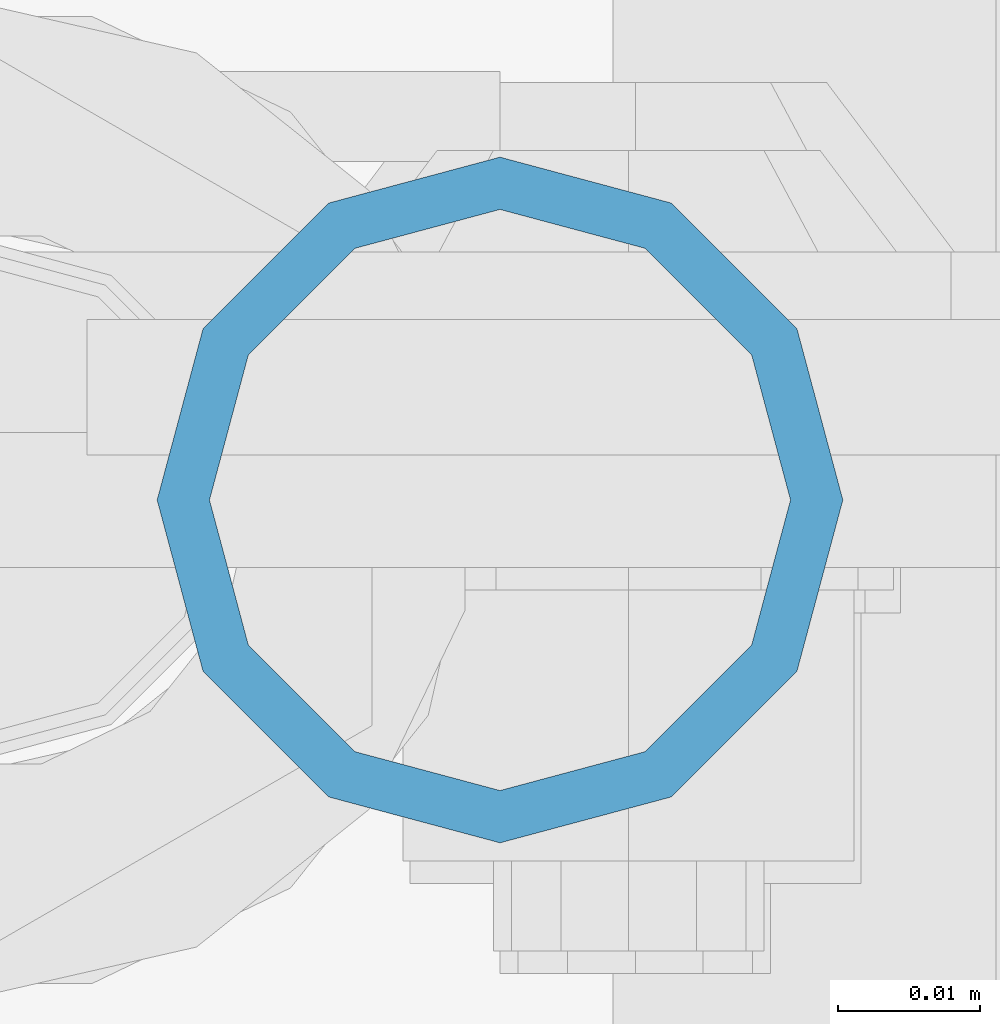
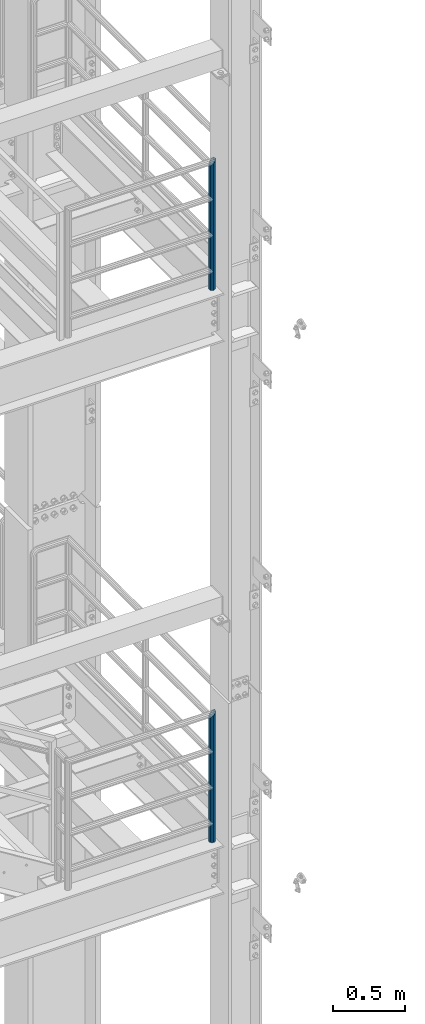
# One storey, part 589 of 1876: 2 columns, 2 elements without a shape of their own.
"""IFC2X3 building model written with IfcOpenShell, lengths in millimetres."""

from ifc_helpers import new_model, si_unit, frame, origin_with_axes, place, context, subcontext, project, spatial, faceted_brep, material, type_object, element, aggregate, save


model = new_model("IFC2X3")

# Units and contexts
model_context = context("Model", 3, precision=1e-05, world=origin_with_axes())
body_context = subcontext(model_context, "Body", "Model", "MODEL_VIEW")
ifc_project = project(units=[si_unit("LENGTHUNIT", "METRE", prefix="MILLI"), si_unit("AREAUNIT", "SQUARE_METRE"), si_unit("VOLUMEUNIT", "CUBIC_METRE"), si_unit("MASSUNIT", "GRAM", prefix="KILO"), si_unit("TIMEUNIT", "SECOND"), si_unit("PLANEANGLEUNIT", "RADIAN"), si_unit("SOLIDANGLEUNIT", "STERADIAN"), si_unit("THERMODYNAMICTEMPERATUREUNIT", "DEGREE_CELSIUS"), si_unit("LUMINOUSINTENSITYUNIT", "LUMEN")], contexts=[model_context])

# Site, building, storey
site_placement = place(None, origin_with_axes())
site = spatial("IfcSite", under=ifc_project, at=site_placement, CompositionType="ELEMENT")
building_placement = place(site_placement, origin_with_axes())
building = spatial("IfcBuilding", under=site, at=building_placement, Name="Undefined", CompositionType="ELEMENT")
storey_placement = place(building_placement, origin_with_axes())
storey = spatial("IfcBuildingStorey", under=building, at=storey_placement, Name="Undefined", CompositionType="ELEMENT", Elevation=0.0)

# Assembly, column
assembly_1_placement = place(storey_placement, origin_with_axes())
assembly_1 = element("IfcElementAssembly", 1, at=assembly_1_placement, inside=storey, Name="RAIL", AssemblyPlace="NOTDEFINED", PredefinedType="RIGID_FRAME")
ifc_material = material()
column_type = type_object("IfcColumnType", Name="PIPE1-1/2SCH40", PredefinedType="NOTDEFINED")
column_1_placement = place(assembly_1_placement, frame((7427.9125, -7112.0, 17983.2), z_axis=(0.0, 1.0, 0.0), x_axis=(0.0, 0.0, 1.0)))
column_1 = element("IfcColumn", 2, at=column_1_placement, type_object=column_type, material=ifc_material, Name="POST", ObjectType="PIPE1-1/2SCH40", context=body_context, shape_type="Brep", body=[
    faceted_brep([(0.0, -20.4469999999999, 0.0), (0.0, -17.7076214311803, 10.2235000000001), (1058.61737856882, -17.7076214311803, 10.2235000000001), (1055.878, -20.4469999999999, 0.0), (0.0, -10.2235000000001, 17.7076214311801), (1066.1015, -10.2235000000001, 17.7076214311801), (-1.45519152283669e-11, 0.0, 20.4470000000001), (1076.325, 0.0, 20.4470000000001), (0.0, 10.2235000000001, 17.7076214311801), (1086.5485, 10.2235000000001, 17.7076214311801), (0.0, 17.7076214311803, 10.2235000000001), (1094.03262143118, 17.7076214311803, 10.2235000000001), (0.0, 20.4469999999999, 0.0), (1096.772, 20.4469999999999, 0.0), (0.0, 17.7076214311803, -10.2235000000001), (1094.03262143118, 17.7076214311803, -10.2235000000001), (0.0, 10.2235000000001, -17.7076214311801), (1086.5485, 10.2235000000001, -17.7076214311801), (-1.45519152283669e-11, 0.0, -20.4470000000001), (1076.325, 0.0, -20.4470000000001), (0.0, -10.2235000000001, -17.7076214311801), (1066.1015, -10.2235000000001, -17.7076214311801), (0.0, -17.7076214311803, -10.2235000000001), (1058.61737856882, -17.7076214311803, -10.2235000000001), (0.0, -24.1299999999992, 0.0), (0.0, -20.8971929933184, -12.0649999999996), (1055.42780700668, -20.8971929933184, -12.0649999999996), (1052.195, -24.1300000000001, 0.0), (0.0, -12.0650000000001, -20.8971929933186), (1064.26, -12.0650000000001, -20.8971929933186), (-1.45519152283669e-11, 0.0, -24.130000000001), (1076.325, 0.0, -24.1300000000001), (0.0, 12.0650000000001, -20.8971929933186), (1088.39, 12.0650000000001, -20.8971929933186), (0.0, 20.8971929933184, -12.0649999999996), (1097.22219299332, 20.8971929933184, -12.0649999999996), (0.0, 24.1299999999992, 0.0), (1100.455, 24.1300000000001, 0.0), (0.0, 20.8971929933184, 12.0649999999996), (1097.22219299332, 20.8971929933184, 12.0649999999996), (0.0, 12.0650000000001, 20.8971929933186), (1088.39, 12.0650000000001, 20.8971929933186), (-1.45519152283669e-11, 0.0, 24.130000000001), (1076.325, 0.0, 24.1300000000001), (0.0, -12.0650000000001, 20.8971929933186), (1064.26, -12.0650000000001, 20.8971929933186), (0.0, -20.8971929933184, 12.0649999999996), (1055.42780700668, -20.8971929933184, 12.0649999999996)], [[[0, 1, 2, 3]], [[1, 4, 5, 2]], [[4, 6, 7, 5]], [[6, 8, 9, 7]], [[8, 10, 11, 9]], [[10, 12, 13, 11]], [[12, 14, 15, 13]], [[14, 16, 17, 15]], [[16, 18, 19, 17]], [[18, 20, 21, 19]], [[20, 22, 23, 21]], [[22, 0, 3, 23]], [[24, 25, 26, 27]], [[25, 28, 29, 26]], [[28, 30, 31, 29]], [[30, 32, 33, 31]], [[32, 34, 35, 33]], [[34, 36, 37, 35]], [[36, 38, 39, 37]], [[38, 40, 41, 39]], [[40, 42, 43, 41]], [[42, 44, 45, 43]], [[44, 46, 47, 45]], [[46, 24, 27, 47]], [[29, 31, 33, 35, 37, 39, 41, 43, 45, 47, 27, 26], [5, 7, 9, 11, 13, 15, 17, 19, 21, 23, 3, 2]], [[46, 44, 42, 40, 38, 36, 34, 32, 30, 28, 25, 24], [22, 20, 18, 16, 14, 12, 10, 8, 6, 4, 1, 0]]]),
])
aggregate(assembly_1, [column_1])

assembly_2_placement = place(storey_placement, origin_with_axes())
assembly_2 = element("IfcElementAssembly", 3, at=assembly_2_placement, inside=storey, Name="RAIL", AssemblyPlace="NOTDEFINED", PredefinedType="RIGID_FRAME")
column_2_placement = place(assembly_2_placement, frame((7427.9125, -7112.0, 13309.6), z_axis=(0.0, 1.0, 0.0), x_axis=(0.0, 0.0, 1.0)))
column_2 = element("IfcColumn", 4, at=column_2_placement, type_object=column_type, material=ifc_material, Name="POST", ObjectType="PIPE1-1/2SCH40", context=body_context, shape_type="Brep", body=[
    faceted_brep([(0.0, -20.4469999999999, 0.0), (0.0, -17.7076214311803, 10.2235000000001), (1058.61737856882, -17.7076214311803, 10.2235000000001), (1055.878, -20.4469999999999, 0.0), (0.0, -10.2235000000001, 17.7076214311801), (1066.1015, -10.2235000000001, 17.7076214311801), (-1.45519152283669e-11, 0.0, 20.4470000000001), (1076.325, 0.0, 20.4470000000001), (0.0, 10.2235000000001, 17.7076214311801), (1086.5485, 10.2235000000001, 17.7076214311801), (0.0, 17.7076214311803, 10.2235000000001), (1094.03262143118, 17.7076214311803, 10.2235000000001), (0.0, 20.4469999999999, 0.0), (1096.772, 20.4469999999999, 0.0), (0.0, 17.7076214311803, -10.2235000000001), (1094.03262143118, 17.7076214311803, -10.2235000000001), (0.0, 10.2235000000001, -17.7076214311801), (1086.5485, 10.2235000000001, -17.7076214311801), (-1.45519152283669e-11, 0.0, -20.4470000000001), (1076.325, 0.0, -20.4470000000001), (0.0, -10.2235000000001, -17.7076214311801), (1066.1015, -10.2235000000001, -17.7076214311801), (0.0, -17.7076214311803, -10.2235000000001), (1058.61737856882, -17.7076214311803, -10.2235000000001), (0.0, -24.1299999999992, 0.0), (0.0, -20.8971929933184, -12.0649999999996), (1055.42780700668, -20.8971929933184, -12.0649999999996), (1052.195, -24.1300000000001, 0.0), (0.0, -12.0650000000001, -20.8971929933186), (1064.26, -12.0650000000001, -20.8971929933186), (-1.45519152283669e-11, 0.0, -24.130000000001), (1076.325, 0.0, -24.1300000000001), (0.0, 12.0650000000001, -20.8971929933186), (1088.39, 12.0650000000001, -20.8971929933186), (0.0, 20.8971929933184, -12.0649999999996), (1097.22219299332, 20.8971929933184, -12.0649999999996), (0.0, 24.1299999999992, 0.0), (1100.455, 24.1300000000001, 0.0), (0.0, 20.8971929933184, 12.0649999999996), (1097.22219299332, 20.8971929933184, 12.0649999999996), (0.0, 12.0650000000001, 20.8971929933186), (1088.39, 12.0650000000001, 20.8971929933186), (-1.45519152283669e-11, 0.0, 24.130000000001), (1076.325, 0.0, 24.1300000000001), (0.0, -12.0650000000001, 20.8971929933186), (1064.26, -12.0650000000001, 20.8971929933186), (0.0, -20.8971929933184, 12.0649999999996), (1055.42780700668, -20.8971929933184, 12.0649999999996)], [[[0, 1, 2, 3]], [[1, 4, 5, 2]], [[4, 6, 7, 5]], [[6, 8, 9, 7]], [[8, 10, 11, 9]], [[10, 12, 13, 11]], [[12, 14, 15, 13]], [[14, 16, 17, 15]], [[16, 18, 19, 17]], [[18, 20, 21, 19]], [[20, 22, 23, 21]], [[22, 0, 3, 23]], [[24, 25, 26, 27]], [[25, 28, 29, 26]], [[28, 30, 31, 29]], [[30, 32, 33, 31]], [[32, 34, 35, 33]], [[34, 36, 37, 35]], [[36, 38, 39, 37]], [[38, 40, 41, 39]], [[40, 42, 43, 41]], [[42, 44, 45, 43]], [[44, 46, 47, 45]], [[46, 24, 27, 47]], [[29, 31, 33, 35, 37, 39, 41, 43, 45, 47, 27, 26], [5, 7, 9, 11, 13, 15, 17, 19, 21, 23, 3, 2]], [[46, 44, 42, 40, 38, 36, 34, 32, 30, 28, 25, 24], [22, 20, 18, 16, 14, 12, 10, 8, 6, 4, 1, 0]]]),
])
aggregate(assembly_2, [column_2])

save(model, "model.ifc")
